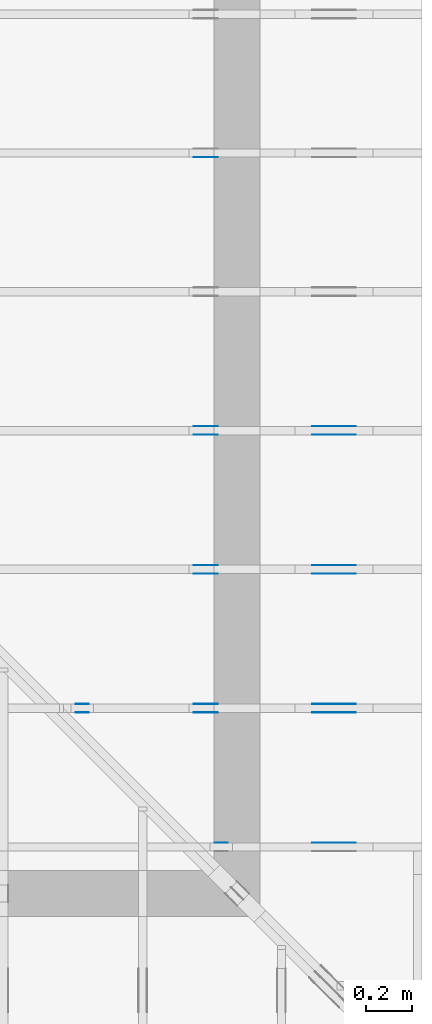
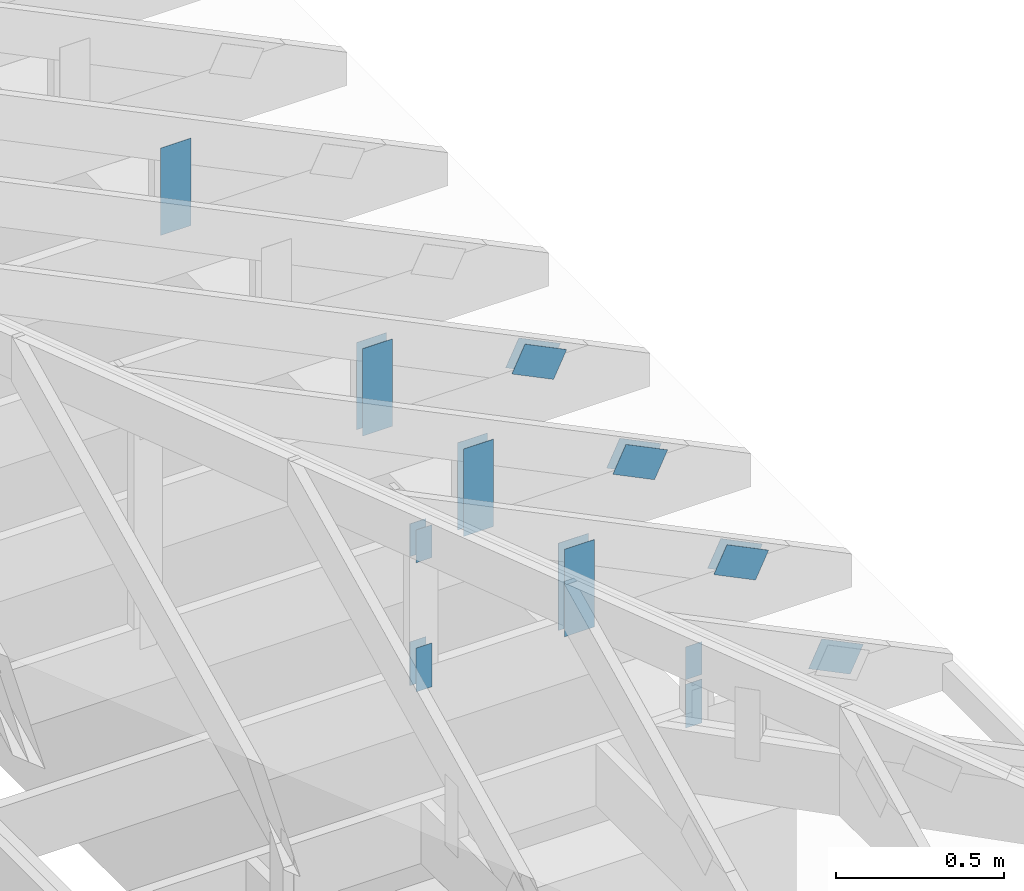
# One storey, part 118 of 159: 20 plates, 5 elements without a shape of their own.
"""IFC2X3 building model written with IfcOpenShell, lengths in millimetres."""

from ifc_helpers import new_model, si_unit, frame, origin, origin_with_axes, origin_2d, place, context, project, spatial, faceted_brep, element, aggregate, save


model = new_model("IFC2X3")

# Units and contexts
model_context = context("Model", 3, precision=1e-05, world=origin())
plan_context = context("Plan", 2, precision=1e-05, world=origin_2d())
ifc_project = project(units=[si_unit("LENGTHUNIT", "METRE", prefix="MILLI"), si_unit("AREAUNIT", "SQUARE_METRE"), si_unit("VOLUMEUNIT", "CUBIC_METRE"), si_unit("SOLIDANGLEUNIT", "STERADIAN"), si_unit("PLANEANGLEUNIT", "RADIAN"), si_unit("MASSUNIT", "GRAM"), si_unit("TIMEUNIT", "SECOND"), si_unit("THERMODYNAMICTEMPERATUREUNIT", "DEGREE_CELSIUS"), si_unit("LUMINOUSINTENSITYUNIT", "LUMEN")], contexts=[model_context, plan_context])

# Site, building, storey
site_placement = place(None, origin_with_axes())
site = spatial("IfcSite", under=ifc_project, at=site_placement, CompositionType="ELEMENT")
building_placement = place(site_placement, origin_with_axes())
building = spatial("IfcBuilding", under=site, at=building_placement, Name="Plan 1", CompositionType="ELEMENT")
storey_placement = place(building_placement, origin_with_axes())
storey = spatial("IfcBuildingStorey", under=building, at=storey_placement, Name="Etasje 1", CompositionType="ELEMENT", Elevation=0.0)

# Assembly, plates
assembly_1_placement = place(storey_placement, frame((21100.012663101486, 318.00740142125824, 1.1021457184401395e-15), z_axis=(1.2246063538223773e-16, 1.0, 6.123031769111886e-17), x_axis=(-1.0, 1.2246063538223773e-16, 0.0)))
assembly_1 = element("IfcElementAssembly", 1, at=assembly_1_placement, inside=storey, Name="S20 (44)", AssemblyPlace="FACTORY", PredefinedType="TRUSS")
plate_1_placement = place(assembly_1_placement, frame((331.11001837099207, 141.86159042547106, 0.0), z_axis=(0.0, 0.0, 1.0), x_axis=(0.8987940462991673, 0.43837114678907685, 0.0)))
plate_1 = element("IfcPlate", 2, at=plate_1_placement, Name="GNT100S 103x159", context=model_context, shape_type="Brep", body=[
    faceted_brep([(158.99998918392998, 103.00001264929405, 1.0), (1.0550605622938747e-05, 103.00001264929405, 1.0), (3.168624004956655e-06, 1.2203795492382596e-05, 1.0), (159.00000923096593, 1.2203795492382596e-05, 1.0), (1.0550605622938747e-05, 103.00001264929405, 1.292033868252489e-21), (158.99998918392998, 103.00001264929405, 1.9471239701232992e-14), (159.00000923096593, 0.0, 1.947124215620575e-14), (3.168624004956655e-06, 0.0, 3.8803170893440275e-22), (159.0000000000001, 1.1148705922106925e-05, 2.6584805324637452e-30), (159.0000000000001, 1.1148705922168155e-05, 1.0), (5.684341886080802e-14, 1.1148705951375017e-05, 1.0), (5.684341886080802e-14, 1.1148705951313786e-05, 0.0), (159.0000000000001, 103.00001114870594, 0.0), (159.0000000000001, 103.00001114870594, 1.0), (159.0000000000001, 1.1148705965524641e-05, 1.0), (159.0000000000001, 1.1148705965524641e-05, 0.0), (-4.861730685829017e-63, 103.00001114870594, 0.0), (-3.7491518045553436e-33, 103.00001114870594, 1.0), (159.0000000000001, 103.00001114870592, 1.0), (159.0000000000001, 103.00001114870592, -7.888609052210118e-31), (5.684342142778951e-14, 1.1148705951313786e-05, -1.5717709276844939e-37), (5.690465174548063e-14, 1.1148705951313786e-05, 1.0), (2.377690857529467e-14, 103.00001114870594, 1.0), (2.3715678257603552e-14, 103.00001114870594, -1.4521185139734257e-30)], [[[0, 1, 2, 3]], [[4, 5, 6, 7]], [[8, 9, 10, 11]], [[12, 13, 14, 15]], [[16, 17, 18, 19]], [[20, 21, 22, 23]]]),
])
plate_2_placement = place(assembly_1_placement, frame((840.5946433071188, 438.23297119140625, 0.0), z_axis=(0.0, 0.0, 1.0), x_axis=(6.123031769111886e-17, -1.0, 0.0)))
plate_2 = element("IfcPlate", 3, at=plate_2_placement, Name="GNT100S 55x119", context=model_context, shape_type="Brep", body=[
    faceted_brep([(119.0, 55.00002222022499, 1.0), (0.0, 55.00002222022499, 1.0), (0.0, 2.2220224991542636e-05, 1.0), (119.0, 2.2220224991542636e-05, 1.0), (0.0, 55.00002222022499, 0.0), (119.0, 55.00002222022499, 1.457281561048629e-14), (119.0, 2.2220224991542636e-05, 1.457281561048629e-14), (0.0, 2.2220224991542636e-05, 0.0), (119.0000108822561, -2.185922541470143e-14, 1.3384473166239481e-30), (119.0000108822561, -2.1797995097010312e-14, 1.0), (1.088225610601512e-05, 6.122831871912316e-17, 1.0), (1.088225610601512e-05, -1.9989719957022716e-21, 1.2239769035249998e-37), (119.0000108822561, 55.0, 0.0), (119.0000108822561, 55.0, 1.0), (119.0000108822561, 0.0, 1.0), (119.0000108822561, 0.0, 0.0), (1.088225610601512e-05, 55.0, 0.0), (1.088225610601512e-05, 55.0, 1.0), (119.0000108822561, 54.99999999999999, 1.0), (119.0000108822561, 54.99999999999999, -3.944304526105059e-31), (1.088225610601512e-05, 0.0, 0.0), (1.088225610607635e-05, -7.498303609110687e-33, 1.0), (1.0882256112811685e-05, 55.0, 1.0), (1.0882256112750455e-05, 55.0, -4.124066764605687e-31)], [[[0, 1, 2, 3]], [[4, 5, 6, 7]], [[8, 9, 10, 11]], [[12, 13, 14, 15]], [[16, 17, 18, 19]], [[20, 21, 22, 23]]]),
])
plate_3_placement = place(assembly_1_placement, frame((895.5946655273438, 143.5, 0.0), z_axis=(0.0, 0.0, 1.0), x_axis=(6.123031769111886e-17, 1.0, 0.0)))
plate_3 = element("IfcPlate", 4, at=plate_3_placement, Name="GNT100S 55x159", context=model_context, shape_type="Brep", body=[
    faceted_brep([(159.0, 55.0, 1.0), (0.0, 55.0, 1.0), (0.0, 0.0, 1.0), (159.0, 0.0, 1.0), (0.0, 55.0, 0.0), (159.0, 55.0, 1.9471241025775798e-14), (159.0, 0.0, 1.9471241025775798e-14), (0.0, 0.0, 0.0), (159.0, 2.2220192447900186e-05, 1.788345383589592e-30), (159.0, 2.2220192447961417e-05, 1.0), (1.1247455413666031e-32, 2.222019247716828e-05, 1.0), (0.0, 2.2220192477107048e-05, 0.0), (159.0, 55.00002222019248, 0.0), (159.0, 55.00002222019248, 1.0), (159.0, 2.2220192477107048e-05, 1.0), (159.0, 2.2220192477107048e-05, 0.0), (0.0, 55.00002222019248, 0.0), (-3.7491518045553436e-33, 55.00002222019248, 1.0), (159.0, 55.00002222019247, 1.0), (159.0, 55.00002222019247, -7.888609052210118e-31), (2.721098889062148e-21, 2.2220192477107048e-05, -1.6661374944622592e-37), (6.123303879000793e-17, 2.2220192477107048e-05, 1.0), (6.796567984813083e-15, 55.00002222019248, 1.0), (6.735337667121964e-15, 55.00002222019248, -4.124068651148373e-31)], [[[0, 1, 2, 3]], [[4, 5, 6, 7]], [[8, 9, 10, 11]], [[12, 13, 14, 15]], [[16, 17, 18, 19]], [[20, 21, 22, 23]]]),
])
aggregate(assembly_1, [plate_1, plate_2, plate_3])

assembly_2_placement = place(storey_placement, frame((21100.012663101486, 918.0074014212582, 1.1021457184401395e-15), z_axis=(1.2246063538223773e-16, 1.0, 6.123031769111886e-17), x_axis=(-1.0, 1.2246063538223773e-16, 0.0)))
assembly_2 = element("IfcElementAssembly", 5, at=assembly_2_placement, inside=storey, Name="S19 (42)", AssemblyPlace="FACTORY", PredefinedType="TRUSS")
plate_4_placement = place(assembly_2_placement, frame((1440.5946044921875, 730.8725134497552, 0.0), z_axis=(0.0, 0.0, 1.0), x_axis=(6.123031769111886e-17, -1.0, 0.0)))
plate_4 = element("IfcPlate", 6, at=plate_4_placement, Name="GNT100S 55x119", context=model_context, shape_type="Brep", body=[
    faceted_brep([(119.00001589116141, 55.0, 1.0), (1.5891161410763743e-05, 55.0, 1.0), (1.5891161410763743e-05, 0.0, 1.0), (119.00001589116141, 0.0, 1.0), (1.5891161410763743e-05, 55.0, 1.9460417233238252e-21), (119.00001589116141, 55.0, 1.4572817556528014e-14), (119.00001589116141, 0.0, 1.4572817556528014e-14), (1.5891161410763743e-05, 0.0, 1.9460417233238252e-21), (119.0, 3.881498648840127e-05, 1.338447208185253e-30), (119.0, 3.88149864884625e-05, 1.0), (1.1247455413666031e-32, 3.8814986510321727e-05, 1.0), (0.0, 3.8814986510260496e-05, 0.0), (119.0, 55.00003881498651, 0.0), (119.0, 55.00003881498651, 1.0), (119.0, 3.8814986510260496e-05, 1.0), (119.0, 3.8814986510260496e-05, 0.0), (0.0, 55.00003881498651, 0.0), (-3.7491518045553436e-33, 55.00003881498651, 1.0), (119.0, 55.0000388149865, 1.0), (119.0, 55.0000388149865, -3.944304526105059e-31), (4.7533079103994866e-21, 3.8814986510260496e-05, -2.910465534374689e-37), (6.123507099902926e-17, 3.8814986510260496e-05, 1.0), (6.7965700170221044e-15, 55.00003881498651, 1.0), (6.7353396993309856e-15, 55.00003881498651, -4.124069895476412e-31)], [[[0, 1, 2, 3]], [[4, 5, 6, 7]], [[8, 9, 10, 11]], [[12, 13, 14, 15]], [[16, 17, 18, 19]], [[20, 21, 22, 23]]]),
])
plate_5_placement = place(assembly_2_placement, frame((1440.5946044921875, 730.8725134497552, -37.0), z_axis=(0.0, 0.0, 1.0), x_axis=(6.123031769111886e-17, -1.0, 0.0)))
plate_5 = element("IfcPlate", 7, at=plate_5_placement, Name="GNT100S 55x119", context=model_context, shape_type="Brep", body=[
    faceted_brep([(119.00001589116141, 55.0, 1.0), (1.5891161410763743e-05, 55.0, 1.0), (1.5891161410763743e-05, 0.0, 1.0), (119.00001589116141, 0.0, 1.0), (1.5891161410763743e-05, 55.0, 1.9460417233238252e-21), (119.00001589116141, 55.0, 1.4572817556528014e-14), (119.00001589116141, 0.0, 1.4572817556528014e-14), (1.5891161410763743e-05, 0.0, 1.9460417233238252e-21), (119.0, 3.881498648840127e-05, 1.338447208185253e-30), (119.0, 3.88149864884625e-05, 1.0), (1.1247455413666031e-32, 3.8814986510321727e-05, 1.0), (0.0, 3.8814986510260496e-05, 0.0), (119.0, 55.00003881498651, 0.0), (119.0, 55.00003881498651, 1.0), (119.0, 3.8814986510260496e-05, 1.0), (119.0, 3.8814986510260496e-05, 0.0), (0.0, 55.00003881498651, 0.0), (-3.7491518045553436e-33, 55.00003881498651, 1.0), (119.0, 55.0000388149865, 1.0), (119.0, 55.0000388149865, -3.944304526105059e-31), (4.7533079103994866e-21, 3.8814986510260496e-05, -2.910465534374689e-37), (6.123507099902926e-17, 3.8814986510260496e-05, 1.0), (6.7965700170221044e-15, 55.00003881498651, 1.0), (6.7353396993309856e-15, 55.00003881498651, -4.124069895476412e-31)], [[[0, 1, 2, 3]], [[4, 5, 6, 7]], [[8, 9, 10, 11]], [[12, 13, 14, 15]], [[16, 17, 18, 19]], [[20, 21, 22, 23]]]),
])
plate_6_placement = place(assembly_2_placement, frame((1495.5946433071513, 143.5, 0.0), z_axis=(0.0, 0.0, 1.0), x_axis=(6.123031769111886e-17, 1.0, 0.0)))
plate_6 = element("IfcPlate", 8, at=plate_6_placement, Name="GNT100S 55x159", context=model_context, shape_type="Brep", body=[
    faceted_brep([(159.00000000000003, 55.00003881496377, 1.0), (0.0, 55.00003881496377, 1.0), (0.0, 3.881496377289295e-05, 1.0), (159.00000000000003, 3.881496377289295e-05, 1.0), (0.0, 55.00003881496377, 0.0), (159.00000000000003, 55.00003881496377, 1.94712410257758e-14), (159.00000000000003, 3.881496377289295e-05, 1.94712410257758e-14), (0.0, 3.881496377289295e-05, 0.0), (159.00000000000003, -2.9206861538663704e-14, 1.7883454107728992e-30), (159.00000000000003, -2.9145631220972585e-14, 1.0), (1.1247455413666031e-32, 6.123031769111886e-17, 1.0), (0.0, 0.0, 0.0), (159.00000000000003, 55.0, 0.0), (159.00000000000003, 55.0, 1.0), (159.00000000000003, 0.0, 1.0), (159.00000000000003, 0.0, 0.0), (0.0, 55.0, 0.0), (-3.7491518045553436e-33, 55.0, 1.0), (159.00000000000003, 54.99999999999999, 1.0), (159.00000000000003, 54.99999999999999, -7.888609052210118e-31), (0.0, 0.0, 0.0), (6.123031769111886e-17, -7.498303609110687e-33, 1.0), (6.796565263714194e-15, 55.0, 1.0), (6.735334946023075e-15, 55.0, -4.124066985010878e-31)], [[[0, 1, 2, 3]], [[4, 5, 6, 7]], [[8, 9, 10, 11]], [[12, 13, 14, 15]], [[16, 17, 18, 19]], [[20, 21, 22, 23]]]),
])
plate_7_placement = place(assembly_2_placement, frame((1495.5946433071513, 143.5, -37.0), z_axis=(0.0, 0.0, 1.0), x_axis=(6.123031769111886e-17, 1.0, 0.0)))
plate_7 = element("IfcPlate", 9, at=plate_7_placement, Name="GNT100S 55x159", context=model_context, shape_type="Brep", body=[
    faceted_brep([(159.00000000000003, 55.00003881496377, 1.0), (0.0, 55.00003881496377, 1.0), (0.0, 3.881496377289295e-05, 1.0), (159.00000000000003, 3.881496377289295e-05, 1.0), (0.0, 55.00003881496377, 0.0), (159.00000000000003, 55.00003881496377, 1.94712410257758e-14), (159.00000000000003, 3.881496377289295e-05, 1.94712410257758e-14), (0.0, 3.881496377289295e-05, 0.0), (159.00000000000003, -2.9206861538663704e-14, 1.7883454107728992e-30), (159.00000000000003, -2.9145631220972585e-14, 1.0), (1.1247455413666031e-32, 6.123031769111886e-17, 1.0), (0.0, 0.0, 0.0), (159.00000000000003, 55.0, 0.0), (159.00000000000003, 55.0, 1.0), (159.00000000000003, 0.0, 1.0), (159.00000000000003, 0.0, 0.0), (0.0, 55.0, 0.0), (-3.7491518045553436e-33, 55.0, 1.0), (159.00000000000003, 54.99999999999999, 1.0), (159.00000000000003, 54.99999999999999, -7.888609052210118e-31), (0.0, 0.0, 0.0), (6.123031769111886e-17, -7.498303609110687e-33, 1.0), (6.796565263714194e-15, 55.0, 1.0), (6.735334946023075e-15, 55.0, -4.124066985010878e-31)], [[[0, 1, 2, 3]], [[4, 5, 6, 7]], [[8, 9, 10, 11]], [[12, 13, 14, 15]], [[16, 17, 18, 19]], [[20, 21, 22, 23]]]),
])
plate_8_placement = place(assembly_2_placement, frame((331.1100183702398, 141.86159042510417, 0.0), z_axis=(0.0, 0.0, 1.0), x_axis=(0.8987940462991671, 0.438371146789077, 0.0)))
plate_8 = element("IfcPlate", 10, at=plate_8_placement, Name="GNT100S 103x159", context=model_context, shape_type="Brep", body=[
    faceted_brep([(158.99998918476706, 103.00001264929404, 1.0), (1.0551442642281472e-05, 103.00001264929404, 1.0), (3.1694609106125426e-06, 1.2203795478171742e-05, 1.0), (159.0000092318029, 1.2203795478171742e-05, 1.0), (1.0551442642281472e-05, 103.00001264929404, 1.2921363701730264e-21), (158.99998918476706, 103.00001264929404, 1.94712397013355e-14), (159.0000092318029, 0.0, 1.9471242156308246e-14), (3.1694609106125426e-06, 0.0, 3.8813419693277774e-22), (159.0, 1.1149114185752038e-05, 1.788345383589592e-30), (159.0, 1.1149114185813268e-05, 1.0), (1.1247455413666031e-32, 1.114911421502013e-05, 1.0), (0.0, 1.11491142149589e-05, 0.0), (159.0, 103.00001114911421, 0.0), (159.0, 103.00001114911421, 1.0), (159.0, 1.11491142149589e-05, 1.0), (159.0, 1.11491142149589e-05, 0.0), (0.0, 103.00001114911421, 0.0), (-3.7491518045553436e-33, 103.00001114911421, 1.0), (159.0, 103.0000111491142, 1.0), (159.0, 103.0000111491142, -7.888609052210118e-31), (1.3653276107130054e-21, 1.11491142149589e-05, -8.359944335641358e-38), (6.123168301872958e-17, 1.11491142149589e-05, 1.0), (1.2674677127389216e-14, 103.00001114911421, 1.0), (1.2613446809698097e-14, 103.00001114911421, -7.723253553378441e-31)], [[[0, 1, 2, 3]], [[4, 5, 6, 7]], [[8, 9, 10, 11]], [[12, 13, 14, 15]], [[16, 17, 18, 19]], [[20, 21, 22, 23]]]),
])
plate_9_placement = place(assembly_2_placement, frame((331.1100183702398, 141.86159042510417, -36.99999999999999), z_axis=(0.0, 0.0, 1.0), x_axis=(0.8987940462991671, 0.438371146789077, 0.0)))
plate_9 = element("IfcPlate", 11, at=plate_9_placement, Name="GNT100S 103x159", context=model_context, shape_type="Brep", body=[
    faceted_brep([(158.99998918476706, 103.00001264929404, 1.0), (1.0551442642281472e-05, 103.00001264929404, 1.0), (3.1694609106125426e-06, 1.2203795478171742e-05, 1.0), (159.0000092318029, 1.2203795478171742e-05, 1.0), (1.0551442642281472e-05, 103.00001264929404, 1.2921363701730264e-21), (158.99998918476706, 103.00001264929404, 1.94712397013355e-14), (159.0000092318029, 0.0, 1.9471242156308246e-14), (3.1694609106125426e-06, 0.0, 3.8813419693277774e-22), (159.0, 1.1149114185752038e-05, 1.788345383589592e-30), (159.0, 1.1149114185813268e-05, 1.0), (1.1247455413666031e-32, 1.114911421502013e-05, 1.0), (0.0, 1.11491142149589e-05, 0.0), (159.0, 103.00001114911421, 0.0), (159.0, 103.00001114911421, 1.0), (159.0, 1.11491142149589e-05, 1.0), (159.0, 1.11491142149589e-05, 0.0), (0.0, 103.00001114911421, 0.0), (-3.7491518045553436e-33, 103.00001114911421, 1.0), (159.0, 103.0000111491142, 1.0), (159.0, 103.0000111491142, -7.888609052210118e-31), (1.3653276107130054e-21, 1.11491142149589e-05, -8.359944335641358e-38), (6.123168301872958e-17, 1.11491142149589e-05, 1.0), (1.2674677127389216e-14, 103.00001114911421, 1.0), (1.2613446809698097e-14, 103.00001114911421, -7.723253553378441e-31)], [[[0, 1, 2, 3]], [[4, 5, 6, 7]], [[8, 9, 10, 11]], [[12, 13, 14, 15]], [[16, 17, 18, 19]], [[20, 21, 22, 23]]]),
])
plate_10_placement = place(assembly_2_placement, frame((986.0125131955604, 165.43966674804688, 0.0), z_axis=(0.0, 0.0, 1.0), x_axis=(6.123031769111886e-17, 1.0, 0.0)))
plate_10 = element("IfcPlate", 12, at=plate_10_placement, Name="GNT100S 103x317", context=model_context, shape_type="Brep", body=[
    faceted_brep([(317.0, 103.00000098852911, 1.0), (0.0, 103.00000098852911, 1.0), (0.0, 9.885291092359694e-07, 1.0), (317.0, 9.885291092359694e-07, 1.0), (0.0, 103.00000098852911, 0.0), (317.0, 103.00000098852911, 3.882002141616936e-14), (317.0, 9.885291092359694e-07, 3.882002141616936e-14), (0.0, 9.885291092359694e-07, 0.0), (317.0000058628158, -5.823003320120026e-14, 3.565443432073891e-30), (317.0000058628158, -5.816880288350914e-14, 1.0), (5.862815783075348e-06, 6.122924074489998e-17, 1.0), (5.862815783075348e-06, -1.0769462188866281e-21, 6.594175911867747e-38), (317.0000058628158, 103.0, 0.0), (317.0000058628158, 103.0, 1.0), (317.0000058628158, 0.0, 1.0), (317.0000058628158, 0.0, 0.0), (5.862815783075348e-06, 103.0, 0.0), (5.862815783075348e-06, 103.0, 1.0), (317.0000058628158, 102.99999999999999, 1.0), (317.0000058628158, 102.99999999999999, -1.5777218104420236e-30), (5.862815783075348e-06, 0.0, 0.0), (5.862815783136578e-06, -7.498303609110687e-33, 1.0), (5.862815795750024e-06, 103.0, 1.0), (5.8628157956887935e-06, 103.0, -7.723252732077687e-31)], [[[0, 1, 2, 3]], [[4, 5, 6, 7]], [[8, 9, 10, 11]], [[12, 13, 14, 15]], [[16, 17, 18, 19]], [[20, 21, 22, 23]]]),
])
plate_11_placement = place(assembly_2_placement, frame((986.0125131955604, 165.43966674804688, -37.0), z_axis=(0.0, 0.0, 1.0), x_axis=(6.123031769111886e-17, 1.0, 0.0)))
plate_11 = element("IfcPlate", 13, at=plate_11_placement, Name="GNT100S 103x317", context=model_context, shape_type="Brep", body=[
    faceted_brep([(317.0, 103.00000098852911, 1.0), (0.0, 103.00000098852911, 1.0), (0.0, 9.885291092359694e-07, 1.0), (317.0, 9.885291092359694e-07, 1.0), (0.0, 103.00000098852911, 0.0), (317.0, 103.00000098852911, 3.882002141616936e-14), (317.0, 9.885291092359694e-07, 3.882002141616936e-14), (0.0, 9.885291092359694e-07, 0.0), (317.0000058628158, -5.823003320120026e-14, 3.565443432073891e-30), (317.0000058628158, -5.816880288350914e-14, 1.0), (5.862815783075348e-06, 6.122924074489998e-17, 1.0), (5.862815783075348e-06, -1.0769462188866281e-21, 6.594175911867747e-38), (317.0000058628158, 103.0, 0.0), (317.0000058628158, 103.0, 1.0), (317.0000058628158, 0.0, 1.0), (317.0000058628158, 0.0, 0.0), (5.862815783075348e-06, 103.0, 0.0), (5.862815783075348e-06, 103.0, 1.0), (317.0000058628158, 102.99999999999999, 1.0), (317.0000058628158, 102.99999999999999, -1.5777218104420236e-30), (5.862815783075348e-06, 0.0, 0.0), (5.862815783136578e-06, -7.498303609110687e-33, 1.0), (5.862815795750024e-06, 103.0, 1.0), (5.8628157956887935e-06, 103.0, -7.723252732077687e-31)], [[[0, 1, 2, 3]], [[4, 5, 6, 7]], [[8, 9, 10, 11]], [[12, 13, 14, 15]], [[16, 17, 18, 19]], [[20, 21, 22, 23]]]),
])
aggregate(assembly_2, [plate_4, plate_5, plate_6, plate_7, plate_8, plate_9, plate_10, plate_11])

# Assembly, plate
assembly_3_placement = place(storey_placement, frame((21100.012663101486, 3318.0074014212582, 1.1021457184401395e-15), z_axis=(1.2246063538223773e-16, 1.0, 6.123031769111886e-17), x_axis=(-1.0, 1.2246063538223773e-16, 0.0)))
assembly_3 = element("IfcElementAssembly", 14, at=assembly_3_placement, inside=storey, Name="S15 (41)", AssemblyPlace="FACTORY", PredefinedType="TRUSS")
plate_12_placement = place(assembly_3_placement, frame((986.0125131962543, 165.43966674804688, -37.0), z_axis=(0.0, 0.0, 1.0), x_axis=(6.123031769111886e-17, 1.0, 0.0)))
plate_12 = element("IfcPlate", 15, at=plate_12_placement, Name="GNT100S 103x317", context=model_context, shape_type="Brep", body=[
    faceted_brep([(317.0, 103.00000098922305, 1.0), (0.0, 103.00000098922305, 1.0), (0.0, 9.892230536934221e-07, 1.0), (317.0, 9.892230536934221e-07, 1.0), (0.0, 103.00000098922305, 0.0), (317.0, 103.00000098922305, 3.882002141616936e-14), (317.0, 9.892230536934221e-07, 3.882002141616936e-14), (0.0, 9.892230536934221e-07, 0.0), (317.0000058628319, -5.823003320120322e-14, 3.565443432074073e-30), (317.0000058628319, -5.81688028835121e-14, 1.0), (5.8628319266063045e-06, 6.122924074193455e-17, 1.0), (5.8628319266063045e-06, -1.0769491843072155e-21, 6.594194069232212e-38), (317.0000058628319, 103.0, 0.0), (317.0000058628319, 103.0, 1.0), (317.0000058628319, 0.0, 1.0), (317.0000058628319, 0.0, 0.0), (5.8628319266063045e-06, 103.0, 0.0), (5.8628319266063045e-06, 103.0, 1.0), (317.0000058628319, 102.99999999999999, 1.0), (317.0000058628319, 102.99999999999999, -1.5777218104420236e-30), (5.8628319266063045e-06, 0.0, 0.0), (5.862831926667535e-06, -7.498303609110687e-33, 1.0), (5.86283193928098e-06, 103.0, 1.0), (5.86283193921975e-06, 103.0, -7.723252732077687e-31)], [[[0, 1, 2, 3]], [[4, 5, 6, 7]], [[8, 9, 10, 11]], [[12, 13, 14, 15]], [[16, 17, 18, 19]], [[20, 21, 22, 23]]]),
])
aggregate(assembly_3, [plate_12])

# Assembly, plates
assembly_4_placement = place(storey_placement, frame((21100.012663101486, 1518.0074014212582, 1.1021457184401395e-15), z_axis=(1.2246063538223773e-16, 1.0, 6.123031769111886e-17), x_axis=(-1.0, 1.2246063538223773e-16, 0.0)))
assembly_4 = element("IfcElementAssembly", 16, at=assembly_4_placement, inside=storey, Name="S18 (40)", AssemblyPlace="FACTORY", PredefinedType="TRUSS")
plate_13_placement = place(assembly_4_placement, frame((331.1100183709922, 141.86159042547115, 0.0), z_axis=(0.0, 0.0, 1.0), x_axis=(0.8987940462991671, 0.4383711467890766, 0.0)))
plate_13 = element("IfcPlate", 17, at=plate_13_placement, Name="GNT100S 103x159", context=model_context, shape_type="Brep", body=[
    faceted_brep([(158.9999891839298, 103.00001264929402, 1.0), (1.055060545240849e-05, 103.00001264929402, 1.0), (3.1686238912698172e-06, 1.2203795449750032e-05, 1.0), (159.00000923096587, 1.2203795449750032e-05, 1.0), (1.055060545240849e-05, 103.00001264929402, 1.2920338473692454e-21), (158.9999891839298, 103.00001264929402, 1.947123970123297e-14), (159.00000923096587, 0.0, 1.9471242156205745e-14), (3.1686238912698172e-06, 0.0, 3.8803169501224037e-22), (158.99999999999994, 1.114870593631778e-05, 3.5286156813378984e-30), (158.99999999999994, 1.114870593637901e-05, 1.0), (1.124750610685991e-32, 1.1148705965585872e-05, 1.0), (0.0, 1.1148705965524641e-05, 0.0), (158.99999999999994, 103.00001114870602, 0.0), (158.99999999999994, 103.00001114870602, 1.0), (158.99999999999994, 1.114870599394635e-05, 1.0), (158.99999999999994, 1.114870599394635e-05, 0.0), (0.0, 103.00001114870598, 0.0), (0.0, 103.00001114870598, 1.0), (158.99999999999994, 103.00001114870601, 1.0), (158.99999999999994, 103.00001114870601, -7.888609052210118e-31), (1.3652776162278917e-21, 1.1148705965524641e-05, -8.359638217820727e-38), (6.123168296873509e-17, 1.1148705965524641e-05, 1.0), (1.2674677127339223e-14, 103.00001114870598, 1.0), (1.2613446809648104e-14, 103.00001114870598, -7.723253553347831e-31)], [[[0, 1, 2, 3]], [[4, 5, 6, 7]], [[8, 9, 10, 11]], [[12, 13, 14, 15]], [[16, 17, 18, 19]], [[20, 21, 22, 23]]]),
])
plate_14_placement = place(assembly_4_placement, frame((331.1100183709922, 141.86159042547115, -37.0), z_axis=(0.0, 0.0, 1.0), x_axis=(0.8987940462991671, 0.4383711467890766, 0.0)))
plate_14 = element("IfcPlate", 18, at=plate_14_placement, Name="GNT100S 103x159", context=model_context, shape_type="Brep", body=[
    faceted_brep([(158.9999891839298, 103.00001264929402, 1.0), (1.055060545240849e-05, 103.00001264929402, 1.0), (3.1686238912698172e-06, 1.2203795449750032e-05, 1.0), (159.00000923096587, 1.2203795449750032e-05, 1.0), (1.055060545240849e-05, 103.00001264929402, 1.2920338473692454e-21), (158.9999891839298, 103.00001264929402, 1.947123970123297e-14), (159.00000923096587, 0.0, 1.9471242156205745e-14), (3.1686238912698172e-06, 0.0, 3.8803169501224037e-22), (158.99999999999994, 1.114870593631778e-05, 3.5286156813378984e-30), (158.99999999999994, 1.114870593637901e-05, 1.0), (1.124750610685991e-32, 1.1148705965585872e-05, 1.0), (0.0, 1.1148705965524641e-05, 0.0), (158.99999999999994, 103.00001114870602, 0.0), (158.99999999999994, 103.00001114870602, 1.0), (158.99999999999994, 1.114870599394635e-05, 1.0), (158.99999999999994, 1.114870599394635e-05, 0.0), (0.0, 103.00001114870598, 0.0), (0.0, 103.00001114870598, 1.0), (158.99999999999994, 103.00001114870601, 1.0), (158.99999999999994, 103.00001114870601, -7.888609052210118e-31), (1.3652776162278917e-21, 1.1148705965524641e-05, -8.359638217820727e-38), (6.123168296873509e-17, 1.1148705965524641e-05, 1.0), (1.2674677127339223e-14, 103.00001114870598, 1.0), (1.2613446809648104e-14, 103.00001114870598, -7.723253553347831e-31)], [[[0, 1, 2, 3]], [[4, 5, 6, 7]], [[8, 9, 10, 11]], [[12, 13, 14, 15]], [[16, 17, 18, 19]], [[20, 21, 22, 23]]]),
])
plate_15_placement = place(assembly_4_placement, frame((986.0125131961968, 165.43966674804688, 0.0), z_axis=(0.0, 0.0, 1.0), x_axis=(6.123031769111886e-17, 1.0, 0.0)))
plate_15 = element("IfcPlate", 19, at=plate_15_placement, Name="GNT100S 103x317", context=model_context, shape_type="Brep", body=[
    faceted_brep([(317.0, 103.00000098916553, 1.0), (0.0, 103.00000098916553, 1.0), (0.0, 9.89165528153535e-07, 1.0), (317.0, 9.89165528153535e-07, 1.0), (0.0, 103.00000098916553, 0.0), (317.0, 103.00000098916553, 3.882002141616936e-14), (317.0, 9.89165528153535e-07, 3.882002141616936e-14), (0.0, 9.89165528153535e-07, 0.0), (317.00000586283056, -5.823003320120297e-14, 3.565443432074057e-30), (317.00000586283056, -5.816880288351185e-14, 1.0), (5.862830562364252e-06, 6.122924074218515e-17, 1.0), (5.862830562364252e-06, -1.0769489337082926e-21, 6.594192534807046e-38), (317.00000586283056, 103.0, 0.0), (317.00000586283056, 103.0, 1.0), (317.00000586283056, 0.0, 1.0), (317.00000586283056, 0.0, 0.0), (5.862830562364252e-06, 103.0, 0.0), (5.862830562364252e-06, 103.0, 1.0), (317.00000586283056, 102.99999999999999, 1.0), (317.00000586283056, 102.99999999999999, -1.5777218104420236e-30), (5.862830562364252e-06, 0.0, 0.0), (5.862830562425482e-06, -7.498303609110687e-33, 1.0), (5.862830575038928e-06, 103.0, 1.0), (5.862830574977697e-06, 103.0, -7.723252732077687e-31)], [[[0, 1, 2, 3]], [[4, 5, 6, 7]], [[8, 9, 10, 11]], [[12, 13, 14, 15]], [[16, 17, 18, 19]], [[20, 21, 22, 23]]]),
])
plate_16_placement = place(assembly_4_placement, frame((986.0125131961968, 165.43966674804688, -37.0), z_axis=(0.0, 0.0, 1.0), x_axis=(6.123031769111886e-17, 1.0, 0.0)))
plate_16 = element("IfcPlate", 20, at=plate_16_placement, Name="GNT100S 103x317", context=model_context, shape_type="Brep", body=[
    faceted_brep([(317.0, 103.00000098916553, 1.0), (0.0, 103.00000098916553, 1.0), (0.0, 9.89165528153535e-07, 1.0), (317.0, 9.89165528153535e-07, 1.0), (0.0, 103.00000098916553, 0.0), (317.0, 103.00000098916553, 3.882002141616936e-14), (317.0, 9.89165528153535e-07, 3.882002141616936e-14), (0.0, 9.89165528153535e-07, 0.0), (317.00000586283056, -5.823003320120297e-14, 3.565443432074057e-30), (317.00000586283056, -5.816880288351185e-14, 1.0), (5.862830562364252e-06, 6.122924074218515e-17, 1.0), (5.862830562364252e-06, -1.0769489337082926e-21, 6.594192534807046e-38), (317.00000586283056, 103.0, 0.0), (317.00000586283056, 103.0, 1.0), (317.00000586283056, 0.0, 1.0), (317.00000586283056, 0.0, 0.0), (5.862830562364252e-06, 103.0, 0.0), (5.862830562364252e-06, 103.0, 1.0), (317.00000586283056, 102.99999999999999, 1.0), (317.00000586283056, 102.99999999999999, -1.5777218104420236e-30), (5.862830562364252e-06, 0.0, 0.0), (5.862830562425482e-06, -7.498303609110687e-33, 1.0), (5.862830575038928e-06, 103.0, 1.0), (5.862830574977697e-06, 103.0, -7.723252732077687e-31)], [[[0, 1, 2, 3]], [[4, 5, 6, 7]], [[8, 9, 10, 11]], [[12, 13, 14, 15]], [[16, 17, 18, 19]], [[20, 21, 22, 23]]]),
])
aggregate(assembly_4, [plate_13, plate_14, plate_15, plate_16])

assembly_5_placement = place(storey_placement, frame((21100.012663101486, 2118.007401421258, 1.1021457184401395e-15), z_axis=(1.2246063538223773e-16, 1.0, 6.123031769111886e-17), x_axis=(-1.0, 1.2246063538223773e-16, 0.0)))
assembly_5 = element("IfcElementAssembly", 21, at=assembly_5_placement, inside=storey, Name="S17 (37)", AssemblyPlace="FACTORY", PredefinedType="TRUSS")
plate_17_placement = place(assembly_5_placement, frame((331.1100183702398, 141.8615904251042, 0.0), z_axis=(0.0, 0.0, 1.0), x_axis=(0.8987940462991671, 0.43837114678907707, 0.0)))
plate_17 = element("IfcPlate", 22, at=plate_17_placement, Name="GNT100S 103x159", context=model_context, shape_type="Brep", body=[
    faceted_brep([(158.999989184767, 103.00001264929404, 1.0), (1.0551442585438053e-05, 103.00001264929404, 1.0), (3.1694608537691238e-06, 1.2203795478171742e-05, 1.0), (159.00000923180284, 1.2203795478171742e-05, 1.0), (1.0551442585438053e-05, 103.00001264929404, 1.2921363632119452e-21), (158.999989184767, 103.00001264929404, 1.9471239701335493e-14), (159.00000923180284, 0.0, 1.947124215630824e-14), (3.1694608537691238e-06, 0.0, 3.8813418997169655e-22), (159.00000000000006, 1.1149114185752038e-05, 4.8075085841285717e-32), (159.00000000000006, 1.1149114185813268e-05, 1.0), (1.124750610685991e-32, 1.114911421502013e-05, 1.0), (0.0, 1.11491142149589e-05, 0.0), (159.00000000000006, 103.00001114911416, 0.0), (159.00000000000006, 103.00001114911416, 1.0), (159.00000000000006, 1.114911418653719e-05, 1.0), (159.00000000000006, 1.114911418653719e-05, 0.0), (5.684341886080802e-14, 103.00001114911417, 0.0), (5.684341886080802e-14, 103.00001114911417, 1.0), (159.00000000000006, 103.00001114911416, 1.0), (159.00000000000006, 103.00001114911416, 0.0), (1.6357970973325136e-22, 1.11491142149589e-05, -1.0016037594788031e-38), (6.12304812708286e-17, 1.11491142149589e-05, 1.0), (5.841586454019774e-14, 103.00001114911417, 1.0), (5.835463422250662e-14, 103.00001114911417, -9.253219669650485e-32)], [[[0, 1, 2, 3]], [[4, 5, 6, 7]], [[8, 9, 10, 11]], [[12, 13, 14, 15]], [[16, 17, 18, 19]], [[20, 21, 22, 23]]]),
])
plate_18_placement = place(assembly_5_placement, frame((331.1100183702398, 141.8615904251042, -37.0), z_axis=(0.0, 0.0, 1.0), x_axis=(0.8987940462991671, 0.43837114678907707, 0.0)))
plate_18 = element("IfcPlate", 23, at=plate_18_placement, Name="GNT100S 103x159", context=model_context, shape_type="Brep", body=[
    faceted_brep([(158.999989184767, 103.00001264929404, 1.0), (1.0551442585438053e-05, 103.00001264929404, 1.0), (3.1694608537691238e-06, 1.2203795478171742e-05, 1.0), (159.00000923180284, 1.2203795478171742e-05, 1.0), (1.0551442585438053e-05, 103.00001264929404, 1.2921363632119452e-21), (158.999989184767, 103.00001264929404, 1.9471239701335493e-14), (159.00000923180284, 0.0, 1.947124215630824e-14), (3.1694608537691238e-06, 0.0, 3.8813418997169655e-22), (159.00000000000006, 1.1149114185752038e-05, 4.8075085841285717e-32), (159.00000000000006, 1.1149114185813268e-05, 1.0), (1.124750610685991e-32, 1.114911421502013e-05, 1.0), (0.0, 1.11491142149589e-05, 0.0), (159.00000000000006, 103.00001114911416, 0.0), (159.00000000000006, 103.00001114911416, 1.0), (159.00000000000006, 1.114911418653719e-05, 1.0), (159.00000000000006, 1.114911418653719e-05, 0.0), (5.684341886080802e-14, 103.00001114911417, 0.0), (5.684341886080802e-14, 103.00001114911417, 1.0), (159.00000000000006, 103.00001114911416, 1.0), (159.00000000000006, 103.00001114911416, 0.0), (1.6357970973325136e-22, 1.11491142149589e-05, -1.0016037594788031e-38), (6.12304812708286e-17, 1.11491142149589e-05, 1.0), (5.841586454019774e-14, 103.00001114911417, 1.0), (5.835463422250662e-14, 103.00001114911417, -9.253219669650485e-32)], [[[0, 1, 2, 3]], [[4, 5, 6, 7]], [[8, 9, 10, 11]], [[12, 13, 14, 15]], [[16, 17, 18, 19]], [[20, 21, 22, 23]]]),
])
plate_19_placement = place(assembly_5_placement, frame((986.012513195702, 165.43966674804688, 0.0), z_axis=(0.0, 0.0, 1.0), x_axis=(6.123031769111886e-17, 1.0, 0.0)))
plate_19 = element("IfcPlate", 24, at=plate_19_placement, Name="GNT100S 103x317", context=model_context, shape_type="Brep", body=[
    faceted_brep([(317.0, 103.00000098867076, 1.0), (0.0, 103.00000098867076, 1.0), (0.0, 9.886707630357705e-07, 1.0), (317.0, 9.886707630357705e-07, 1.0), (0.0, 103.00000098867076, 0.0), (317.0, 103.00000098867076, 3.882002141616936e-14), (317.0, 9.886707630357705e-07, 3.882002141616936e-14), (0.0, 9.886707630357705e-07, 0.0), (317.0000058628192, -5.823003320120089e-14, 3.565443432073929e-30), (317.0000058628192, -5.816880288350977e-14, 1.0), (5.86281919368048e-06, 6.122924074427348e-17, 1.0), (5.86281919368048e-06, -1.0769468453839353e-21, 6.594179747930662e-38), (317.0000058628192, 103.0, 0.0), (317.0000058628192, 103.0, 1.0), (317.0000058628192, 0.0, 1.0), (317.0000058628192, 0.0, 0.0), (5.86281919368048e-06, 103.0, 0.0), (5.86281919368048e-06, 103.0, 1.0), (317.0000058628192, 102.99999999999999, 1.0), (317.0000058628192, 102.99999999999999, -1.5777218104420236e-30), (5.86281919368048e-06, 0.0, 0.0), (5.86281919374171e-06, -7.498303609110687e-33, 1.0), (5.862819206355155e-06, 103.0, 1.0), (5.862819206293925e-06, 103.0, -7.723252732077687e-31)], [[[0, 1, 2, 3]], [[4, 5, 6, 7]], [[8, 9, 10, 11]], [[12, 13, 14, 15]], [[16, 17, 18, 19]], [[20, 21, 22, 23]]]),
])
plate_20_placement = place(assembly_5_placement, frame((986.012513195702, 165.43966674804688, -37.0), z_axis=(0.0, 0.0, 1.0), x_axis=(6.123031769111886e-17, 1.0, 0.0)))
plate_20 = element("IfcPlate", 25, at=plate_20_placement, Name="GNT100S 103x317", context=model_context, shape_type="Brep", body=[
    faceted_brep([(317.0, 103.00000098867076, 1.0), (0.0, 103.00000098867076, 1.0), (0.0, 9.886707630357705e-07, 1.0), (317.0, 9.886707630357705e-07, 1.0), (0.0, 103.00000098867076, 0.0), (317.0, 103.00000098867076, 3.882002141616936e-14), (317.0, 9.886707630357705e-07, 3.882002141616936e-14), (0.0, 9.886707630357705e-07, 0.0), (317.0000058628192, -5.823003320120089e-14, 3.565443432073929e-30), (317.0000058628192, -5.816880288350977e-14, 1.0), (5.86281919368048e-06, 6.122924074427348e-17, 1.0), (5.86281919368048e-06, -1.0769468453839353e-21, 6.594179747930662e-38), (317.0000058628192, 103.0, 0.0), (317.0000058628192, 103.0, 1.0), (317.0000058628192, 0.0, 1.0), (317.0000058628192, 0.0, 0.0), (5.86281919368048e-06, 103.0, 0.0), (5.86281919368048e-06, 103.0, 1.0), (317.0000058628192, 102.99999999999999, 1.0), (317.0000058628192, 102.99999999999999, -1.5777218104420236e-30), (5.86281919368048e-06, 0.0, 0.0), (5.86281919374171e-06, -7.498303609110687e-33, 1.0), (5.862819206355155e-06, 103.0, 1.0), (5.862819206293925e-06, 103.0, -7.723252732077687e-31)], [[[0, 1, 2, 3]], [[4, 5, 6, 7]], [[8, 9, 10, 11]], [[12, 13, 14, 15]], [[16, 17, 18, 19]], [[20, 21, 22, 23]]]),
])
aggregate(assembly_5, [plate_17, plate_18, plate_19, plate_20])

save(model, "model.ifc")
